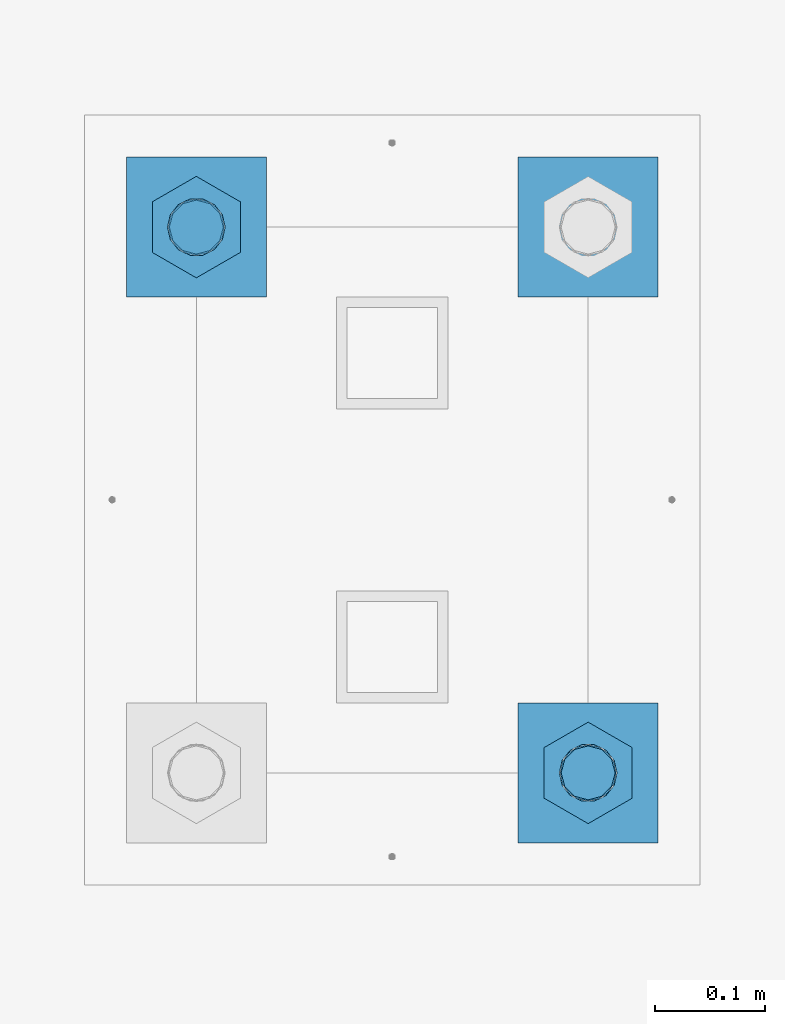
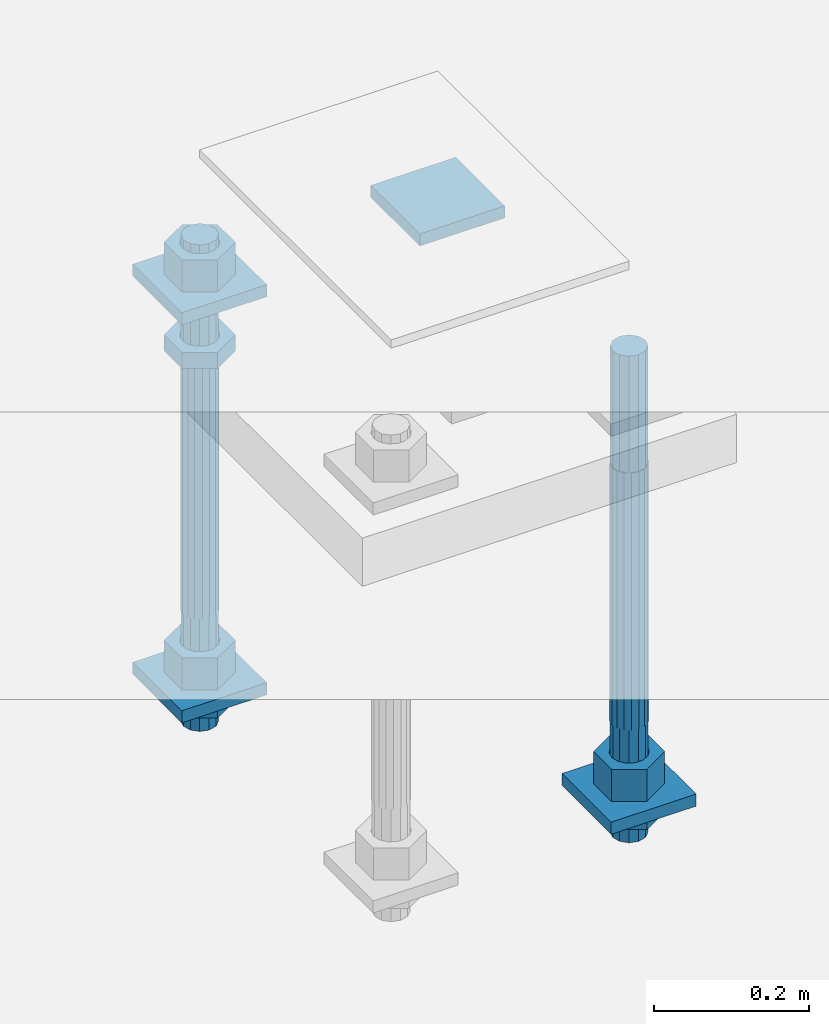
# One storey, part 2764 of 3843: 12 beams, 1 element without a shape of its own.
"""IFC2X3 building model written with IfcOpenShell, lengths in millimetres."""

from ifc_helpers import new_model, si_unit, frame, origin_with_axes, place, context, subcontext, project, spatial, faceted_brep, material, type_object, element, aggregate, save


model = new_model("IFC2X3")

# Units and contexts
model_context = context("Model", 3, precision=1e-05, world=origin_with_axes())
body_context = subcontext(model_context, "Body", "Model", "MODEL_VIEW")
ifc_project = project(units=[si_unit("LENGTHUNIT", "METRE", prefix="MILLI"), si_unit("AREAUNIT", "SQUARE_METRE"), si_unit("VOLUMEUNIT", "CUBIC_METRE"), si_unit("MASSUNIT", "GRAM", prefix="KILO"), si_unit("TIMEUNIT", "SECOND"), si_unit("PLANEANGLEUNIT", "RADIAN"), si_unit("SOLIDANGLEUNIT", "STERADIAN"), si_unit("THERMODYNAMICTEMPERATUREUNIT", "DEGREE_CELSIUS"), si_unit("LUMINOUSINTENSITYUNIT", "LUMEN")], contexts=[model_context])

# Site, building, storey
site_placement = place(None, origin_with_axes())
site = spatial("IfcSite", under=ifc_project, at=site_placement, CompositionType="ELEMENT")
building_placement = place(site_placement, origin_with_axes())
building = spatial("IfcBuilding", under=site, at=building_placement, Name="Undefined", CompositionType="ELEMENT")
storey_placement = place(building_placement, origin_with_axes())
storey = spatial("IfcBuildingStorey", under=building, at=storey_placement, Name="Undefined", CompositionType="ELEMENT", Elevation=0.0)

# Assembly, beams
assembly_placement = place(storey_placement, origin_with_axes())
assembly = element("IfcElementAssembly", 1, at=assembly_placement, inside=storey, Name="TEMPLATE", AssemblyPlace="NOTDEFINED", PredefinedType="RIGID_FRAME")
ifc_material_1 = material(Name="STEEL/A572-50")
beam_type_1 = type_object("IfcBeamType", PredefinedType="NOTDEFINED")
beam_1_placement = place(assembly_placement, frame((111798.100001526, 52952.65, 29873.575), z_axis=(0.0, -1.0, 0.0), x_axis=(1.0, 0.0, 0.0)))
beam_1 = element("IfcBeam", 2, at=beam_1_placement, type_object=beam_type_1, material=ifc_material_1, Name="WASHER_PLATE", context=body_context, shape_type="Brep", body=[
    faceted_brep([(0.0, 9.52500000000146, -63.5), (0.0, 9.52500000000146, 63.5), (127.0, 9.52500000000146, 63.5), (127.0, 9.52500000000146, -63.5), (0.0, -9.52500000000146, 63.5), (127.0, -9.52500000000146, 63.5), (0.0, -9.52500000000146, -63.5), (127.0, -9.52500000000146, -63.5)], [[[0, 1, 2, 3]], [[1, 4, 5, 2]], [[4, 6, 7, 5]], [[6, 0, 3, 7]], [[5, 7, 3, 2]], [[6, 4, 1, 0]]]),
])
beam_2_placement = place(assembly_placement, frame((112153.700001526, 52952.65, 29873.575), z_axis=(0.0, -1.0, 0.0), x_axis=(1.0, 0.0, 0.0)))
beam_2 = element("IfcBeam", 3, at=beam_2_placement, type_object=beam_type_1, material=ifc_material_1, Name="WASHER_PLATE", context=body_context, shape_type="Brep", body=[
    faceted_brep([(0.0, 9.52500000000146, -63.5), (0.0, 9.52500000000146, 63.5), (127.0, 9.52500000000146, 63.5), (127.0, 9.52500000000146, -63.5), (0.0, -9.52500000000146, 63.5), (127.0, -9.52500000000146, 63.5), (0.0, -9.52500000000146, -63.5), (127.0, -9.52500000000146, -63.5)], [[[0, 1, 2, 3]], [[1, 4, 5, 2]], [[4, 6, 7, 5]], [[6, 0, 3, 7]], [[5, 7, 3, 2]], [[6, 4, 1, 0]]]),
])
beam_3_placement = place(assembly_placement, frame((111798.100001526, 52952.65, 29244.925), z_axis=(0.0, -1.0, 0.0), x_axis=(1.0, 0.0, 0.0)))
beam_3 = element("IfcBeam", 4, at=beam_3_placement, type_object=beam_type_1, material=ifc_material_1, Name="WASHER_PLATE", context=body_context, shape_type="Brep", body=[
    faceted_brep([(0.0, 9.52500000000146, -63.5), (0.0, 9.52500000000146, 63.5), (127.0, 9.52500000000146, 63.5), (127.0, 9.52500000000146, -63.5), (0.0, -9.52500000000146, 63.5), (127.0, -9.52500000000146, 63.5), (0.0, -9.52500000000146, -63.5), (127.0, -9.52500000000146, -63.5)], [[[0, 1, 2, 3]], [[1, 4, 5, 2]], [[4, 6, 7, 5]], [[6, 0, 3, 7]], [[5, 7, 3, 2]], [[6, 4, 1, 0]]]),
])
beam_4_placement = place(assembly_placement, frame((112153.700001526, 52457.35, 29244.925), z_axis=(0.0, -1.0, 0.0), x_axis=(1.0, 0.0, 0.0)))
beam_4 = element("IfcBeam", 5, at=beam_4_placement, type_object=beam_type_1, material=ifc_material_1, Name="WASHER_PLATE", context=body_context, shape_type="Brep", body=[
    faceted_brep([(0.0, 9.52500000000146, -63.5), (0.0, 9.52500000000146, 63.5), (127.0, 9.52500000000146, 63.5), (127.0, 9.52500000000146, -63.5), (0.0, -9.52500000000146, 63.5), (127.0, -9.52500000000146, 63.5), (0.0, -9.52500000000146, -63.5), (127.0, -9.52500000000146, -63.5)], [[[0, 1, 2, 3]], [[1, 4, 5, 2]], [[4, 6, 7, 5]], [[6, 0, 3, 7]], [[5, 7, 3, 2]], [[6, 4, 1, 0]]]),
])
ifc_material_2 = material(Name="STEEL/A36")
beam_type_2 = type_object("IfcBeamType", Name="2_HALF_NUT", PredefinedType="NOTDEFINED")
beam_5_placement = place(assembly_placement, frame((111861.600001526, 52952.65, 29787.85), z_axis=(1.0, 0.0, 0.0), x_axis=(0.0, 0.0, -1.0)))
beam_5 = element("IfcBeam", 6, at=beam_5_placement, type_object=beam_type_2, material=ifc_material_2, Name="NUT", ObjectType="2_HALF_NUT", context=body_context, shape_type="Brep", body=[
    faceted_brep([(0.0, -46.0369987487793, 0.0), (0.0, -23.0184993743896, -39.869213104248), (25.4000000000015, -23.0184993743896, -39.869213104248), (25.4000000000015, -46.0369987487793, 0.0), (0.0, 23.0184993743896, -39.869213104248), (25.4000000000015, 23.0184993743896, -39.869213104248), (0.0, 46.0369987487793, 0.0), (25.4000000000015, 46.0369987487793, 0.0), (0.0, 23.0184993743896, 39.869213104248), (25.4000000000015, 23.0184993743896, 39.869213104248), (0.0, -23.0184993743896, 39.869213104248), (25.4000000000015, -23.0184993743896, 39.869213104248), (0.0, 0.0, 26.1940002441406), (0.0, 11.3650617044477, 23.5999013092805), (25.4000000000015, 11.3650617044477, 23.5999013092805), (25.4000000000015, 0.0, 26.1940002441406), (0.0, 20.4791109456419, 16.3316083006721), (25.4000000000015, 20.4791109456419, 16.3316083006721), (0.0, 25.5370200498292, 5.82867859874386), (25.4000000000015, 25.5370200498292, 5.82867859874386), (0.0, 25.5370200498292, -5.82867859874386), (25.4000000000015, 25.5370200498292, -5.82867859874386), (0.0, 20.4791109456419, -16.3316083006721), (25.4000000000015, 20.4791109456419, -16.3316083006721), (0.0, 11.3650617044477, -23.5999013092805), (25.4000000000015, 11.3650617044477, -23.5999013092805), (0.0, 0.0, -26.1940002441406), (25.4000000000015, 0.0, -26.1940002441406), (0.0, -11.3650617044477, -23.5999013092805), (25.4000000000015, -11.3650617044477, -23.5999013092805), (0.0, -20.4791109456419, -16.3316083006721), (25.4000000000015, -20.4791109456419, -16.3316083006721), (0.0, -25.5370200498292, -5.82867859874386), (25.4000000000015, -25.5370200498292, -5.82867859874386), (0.0, -25.5370200498292, 5.82867859874386), (25.4000000000015, -25.5370200498292, 5.82867859874386), (0.0, -20.4791109456419, 16.3316083006721), (25.4000000000015, -20.4791109456419, 16.3316083006721), (0.0, -11.3650617044477, 23.5999013092805), (25.4000000000015, -11.3650617044477, 23.5999013092805)], [[[0, 1, 2, 3]], [[1, 4, 5, 2]], [[4, 6, 7, 5]], [[6, 8, 9, 7]], [[8, 10, 11, 9]], [[10, 0, 3, 11]], [[12, 13, 14, 15]], [[13, 16, 17, 14]], [[16, 18, 19, 17]], [[18, 20, 21, 19]], [[20, 22, 23, 21]], [[22, 24, 25, 23]], [[24, 26, 27, 25]], [[26, 28, 29, 27]], [[28, 30, 31, 29]], [[30, 32, 33, 31]], [[32, 34, 35, 33]], [[34, 36, 37, 35]], [[36, 38, 39, 37]], [[38, 12, 15, 39]], [[5, 7, 9, 11, 3, 2], [17, 19, 21, 23, 25, 27, 29, 31, 33, 35, 37, 39, 15, 14]], [[10, 8, 6, 4, 1, 0], [38, 36, 34, 32, 30, 28, 26, 24, 22, 20, 18, 16, 13, 12]]]),
])
beam_6_placement = place(assembly_placement, frame((111861.600001526, 52952.65, 29235.4), z_axis=(1.0, 0.0, 0.0), x_axis=(0.0, 0.0, -1.0)))
beam_6 = element("IfcBeam", 7, at=beam_6_placement, type_object=beam_type_2, material=ifc_material_2, Name="NUT", ObjectType="2_HALF_NUT", context=body_context, shape_type="Brep", body=[
    faceted_brep([(0.0, -46.0369987487793, 0.0), (0.0, -23.0184993743896, -39.869213104248), (25.4000000000015, -23.0184993743896, -39.869213104248), (25.4000000000015, -46.0369987487793, 0.0), (0.0, 23.0184993743896, -39.869213104248), (25.4000000000015, 23.0184993743896, -39.869213104248), (0.0, 46.0369987487793, 0.0), (25.4000000000015, 46.0369987487793, 0.0), (0.0, 23.0184993743896, 39.869213104248), (25.4000000000015, 23.0184993743896, 39.869213104248), (0.0, -23.0184993743896, 39.869213104248), (25.4000000000015, -23.0184993743896, 39.869213104248), (0.0, 0.0, 26.1940002441406), (0.0, 11.3650617044477, 23.5999013092805), (25.4000000000015, 11.3650617044477, 23.5999013092805), (25.4000000000015, 0.0, 26.1940002441406), (0.0, 20.4791109456419, 16.3316083006721), (25.4000000000015, 20.4791109456419, 16.3316083006721), (0.0, 25.5370200498292, 5.82867859874386), (25.4000000000015, 25.5370200498292, 5.82867859874386), (0.0, 25.5370200498292, -5.82867859874386), (25.4000000000015, 25.5370200498292, -5.82867859874386), (0.0, 20.4791109456419, -16.3316083006721), (25.4000000000015, 20.4791109456419, -16.3316083006721), (0.0, 11.3650617044477, -23.5999013092805), (25.4000000000015, 11.3650617044477, -23.5999013092805), (0.0, 0.0, -26.1940002441406), (25.4000000000015, 0.0, -26.1940002441406), (0.0, -11.3650617044477, -23.5999013092805), (25.4000000000015, -11.3650617044477, -23.5999013092805), (0.0, -20.4791109456419, -16.3316083006721), (25.4000000000015, -20.4791109456419, -16.3316083006721), (0.0, -25.5370200498292, -5.82867859874386), (25.4000000000015, -25.5370200498292, -5.82867859874386), (0.0, -25.5370200498292, 5.82867859874386), (25.4000000000015, -25.5370200498292, 5.82867859874386), (0.0, -20.4791109456419, 16.3316083006721), (25.4000000000015, -20.4791109456419, 16.3316083006721), (0.0, -11.3650617044477, 23.5999013092805), (25.4000000000015, -11.3650617044477, 23.5999013092805)], [[[0, 1, 2, 3]], [[1, 4, 5, 2]], [[4, 6, 7, 5]], [[6, 8, 9, 7]], [[8, 10, 11, 9]], [[10, 0, 3, 11]], [[12, 13, 14, 15]], [[13, 16, 17, 14]], [[16, 18, 19, 17]], [[18, 20, 21, 19]], [[20, 22, 23, 21]], [[22, 24, 25, 23]], [[24, 26, 27, 25]], [[26, 28, 29, 27]], [[28, 30, 31, 29]], [[30, 32, 33, 31]], [[32, 34, 35, 33]], [[34, 36, 37, 35]], [[36, 38, 39, 37]], [[38, 12, 15, 39]], [[5, 7, 9, 11, 3, 2], [17, 19, 21, 23, 25, 27, 29, 31, 33, 35, 37, 39, 15, 14]], [[10, 8, 6, 4, 1, 0], [38, 36, 34, 32, 30, 28, 26, 24, 22, 20, 18, 16, 13, 12]]]),
])
beam_7_placement = place(assembly_placement, frame((112217.200001526, 52457.35, 29235.4), z_axis=(1.0, 0.0, 0.0), x_axis=(0.0, 0.0, -1.0)))
beam_7 = element("IfcBeam", 8, at=beam_7_placement, type_object=beam_type_2, material=ifc_material_2, Name="NUT", ObjectType="2_HALF_NUT", context=body_context, shape_type="Brep", body=[
    faceted_brep([(0.0, -46.0369987487793, 0.0), (0.0, -23.0184993743896, -39.869213104248), (25.4000000000015, -23.0184993743896, -39.869213104248), (25.4000000000015, -46.0369987487793, 0.0), (0.0, 23.0184993743896, -39.869213104248), (25.4000000000015, 23.0184993743896, -39.869213104248), (0.0, 46.0369987487793, 0.0), (25.4000000000015, 46.0369987487793, 0.0), (0.0, 23.0184993743896, 39.869213104248), (25.4000000000015, 23.0184993743896, 39.869213104248), (0.0, -23.0184993743896, 39.869213104248), (25.4000000000015, -23.0184993743896, 39.869213104248), (0.0, 0.0, 26.1940002441406), (0.0, 11.3650617044477, 23.5999013092805), (25.4000000000015, 11.3650617044477, 23.5999013092805), (25.4000000000015, 0.0, 26.1940002441406), (0.0, 20.4791109456419, 16.3316083006721), (25.4000000000015, 20.4791109456419, 16.3316083006721), (0.0, 25.5370200498292, 5.82867859874386), (25.4000000000015, 25.5370200498292, 5.82867859874386), (0.0, 25.5370200498292, -5.82867859874386), (25.4000000000015, 25.5370200498292, -5.82867859874386), (0.0, 20.4791109456419, -16.3316083006721), (25.4000000000015, 20.4791109456419, -16.3316083006721), (0.0, 11.3650617044477, -23.5999013092805), (25.4000000000015, 11.3650617044477, -23.5999013092805), (0.0, 0.0, -26.1940002441406), (25.4000000000015, 0.0, -26.1940002441406), (0.0, -11.3650617044477, -23.5999013092805), (25.4000000000015, -11.3650617044477, -23.5999013092805), (0.0, -20.4791109456419, -16.3316083006721), (25.4000000000015, -20.4791109456419, -16.3316083006721), (0.0, -25.5370200498292, -5.82867859874386), (25.4000000000015, -25.5370200498292, -5.82867859874386), (0.0, -25.5370200498292, 5.82867859874386), (25.4000000000015, -25.5370200498292, 5.82867859874386), (0.0, -20.4791109456419, 16.3316083006721), (25.4000000000015, -20.4791109456419, 16.3316083006721), (0.0, -11.3650617044477, 23.5999013092805), (25.4000000000015, -11.3650617044477, 23.5999013092805)], [[[0, 1, 2, 3]], [[1, 4, 5, 2]], [[4, 6, 7, 5]], [[6, 8, 9, 7]], [[8, 10, 11, 9]], [[10, 0, 3, 11]], [[12, 13, 14, 15]], [[13, 16, 17, 14]], [[16, 18, 19, 17]], [[18, 20, 21, 19]], [[20, 22, 23, 21]], [[22, 24, 25, 23]], [[24, 26, 27, 25]], [[26, 28, 29, 27]], [[28, 30, 31, 29]], [[30, 32, 33, 31]], [[32, 34, 35, 33]], [[34, 36, 37, 35]], [[36, 38, 39, 37]], [[38, 12, 15, 39]], [[5, 7, 9, 11, 3, 2], [17, 19, 21, 23, 25, 27, 29, 31, 33, 35, 37, 39, 15, 14]], [[10, 8, 6, 4, 1, 0], [38, 36, 34, 32, 30, 28, 26, 24, 22, 20, 18, 16, 13, 12]]]),
])
beam_type_3 = type_object("IfcBeamType", Name="2_HEAVY_HEX_NUT", PredefinedType="NOTDEFINED")
beam_8_placement = place(assembly_placement, frame((111861.600001526, 52952.65, 29933.9), z_axis=(1.0, 0.0, 0.0), x_axis=(0.0, 0.0, -1.0)))
beam_8 = element("IfcBeam", 9, at=beam_8_placement, type_object=beam_type_3, material=ifc_material_2, Name="NUT", ObjectType="2_HEAVY_HEX_NUT", context=body_context, shape_type="Brep", body=[
    faceted_brep([(0.0, -46.0369987487793, 0.0), (0.0, -23.0184993743896, -39.869213104248), (50.7999999999993, -23.0184993743896, -39.869213104248), (50.7999999999993, -46.0369987487793, 0.0), (0.0, 23.0184993743896, -39.869213104248), (50.7999999999993, 23.0184993743896, -39.869213104248), (0.0, 46.0369987487793, 0.0), (50.7999999999993, 46.0369987487793, 0.0), (0.0, 23.0184993743896, 39.869213104248), (50.7999999999993, 23.0184993743896, 39.869213104248), (0.0, -23.0184993743896, 39.869213104248), (50.7999999999993, -23.0184993743896, 39.869213104248), (0.0, 0.0, 26.1940002441406), (0.0, 11.3650617044477, 23.5999013092805), (50.7999999999993, 11.3650617044477, 23.5999013092805), (50.7999999999993, 0.0, 26.1940002441406), (0.0, 20.4791109456419, 16.3316083006721), (50.7999999999993, 20.4791109456419, 16.3316083006721), (0.0, 25.5370200498292, 5.82867859874386), (50.7999999999993, 25.5370200498292, 5.82867859874386), (0.0, 25.5370200498292, -5.82867859874386), (50.7999999999993, 25.5370200498292, -5.82867859874386), (0.0, 20.4791109456419, -16.3316083006721), (50.7999999999993, 20.4791109456419, -16.3316083006721), (0.0, 11.3650617044477, -23.5999013092805), (50.7999999999993, 11.3650617044477, -23.5999013092805), (0.0, 0.0, -26.1940002441406), (50.7999999999993, 0.0, -26.1940002441406), (0.0, -11.3650617044477, -23.5999013092805), (50.7999999999993, -11.3650617044477, -23.5999013092805), (0.0, -20.4791109456419, -16.3316083006721), (50.7999999999993, -20.4791109456419, -16.3316083006721), (0.0, -25.5370200498292, -5.82867859874386), (50.7999999999993, -25.5370200498292, -5.82867859874386), (0.0, -25.5370200498292, 5.82867859874386), (50.7999999999993, -25.5370200498292, 5.82867859874386), (0.0, -20.4791109456419, 16.3316083006721), (50.7999999999993, -20.4791109456419, 16.3316083006721), (0.0, -11.3650617044477, 23.5999013092805), (50.7999999999993, -11.3650617044477, 23.5999013092805)], [[[0, 1, 2, 3]], [[1, 4, 5, 2]], [[4, 6, 7, 5]], [[6, 8, 9, 7]], [[8, 10, 11, 9]], [[10, 0, 3, 11]], [[12, 13, 14, 15]], [[13, 16, 17, 14]], [[16, 18, 19, 17]], [[18, 20, 21, 19]], [[20, 22, 23, 21]], [[22, 24, 25, 23]], [[24, 26, 27, 25]], [[26, 28, 29, 27]], [[28, 30, 31, 29]], [[30, 32, 33, 31]], [[32, 34, 35, 33]], [[34, 36, 37, 35]], [[36, 38, 39, 37]], [[38, 12, 15, 39]], [[5, 7, 9, 11, 3, 2], [17, 19, 21, 23, 25, 27, 29, 31, 33, 35, 37, 39, 15, 14]], [[10, 8, 6, 4, 1, 0], [38, 36, 34, 32, 30, 28, 26, 24, 22, 20, 18, 16, 13, 12]]]),
])
beam_9_placement = place(assembly_placement, frame((111861.600001526, 52952.65, 29305.25), z_axis=(1.0, 0.0, 0.0), x_axis=(0.0, 0.0, -1.0)))
beam_9 = element("IfcBeam", 10, at=beam_9_placement, type_object=beam_type_3, material=ifc_material_2, Name="NUT", ObjectType="2_HEAVY_HEX_NUT", context=body_context, shape_type="Brep", body=[
    faceted_brep([(0.0, -46.0369987487793, 0.0), (0.0, -23.0184993743896, -39.869213104248), (50.7999999999993, -23.0184993743896, -39.869213104248), (50.7999999999993, -46.0369987487793, 0.0), (0.0, 23.0184993743896, -39.869213104248), (50.7999999999993, 23.0184993743896, -39.869213104248), (0.0, 46.0369987487793, 0.0), (50.7999999999993, 46.0369987487793, 0.0), (0.0, 23.0184993743896, 39.869213104248), (50.7999999999993, 23.0184993743896, 39.869213104248), (0.0, -23.0184993743896, 39.869213104248), (50.7999999999993, -23.0184993743896, 39.869213104248), (0.0, 0.0, 26.1940002441406), (0.0, 11.3650617044477, 23.5999013092805), (50.7999999999993, 11.3650617044477, 23.5999013092805), (50.7999999999993, 0.0, 26.1940002441406), (0.0, 20.4791109456419, 16.3316083006721), (50.7999999999993, 20.4791109456419, 16.3316083006721), (0.0, 25.5370200498292, 5.82867859874386), (50.7999999999993, 25.5370200498292, 5.82867859874386), (0.0, 25.5370200498292, -5.82867859874386), (50.7999999999993, 25.5370200498292, -5.82867859874386), (0.0, 20.4791109456419, -16.3316083006721), (50.7999999999993, 20.4791109456419, -16.3316083006721), (0.0, 11.3650617044477, -23.5999013092805), (50.7999999999993, 11.3650617044477, -23.5999013092805), (0.0, 0.0, -26.1940002441406), (50.7999999999993, 0.0, -26.1940002441406), (0.0, -11.3650617044477, -23.5999013092805), (50.7999999999993, -11.3650617044477, -23.5999013092805), (0.0, -20.4791109456419, -16.3316083006721), (50.7999999999993, -20.4791109456419, -16.3316083006721), (0.0, -25.5370200498292, -5.82867859874386), (50.7999999999993, -25.5370200498292, -5.82867859874386), (0.0, -25.5370200498292, 5.82867859874386), (50.7999999999993, -25.5370200498292, 5.82867859874386), (0.0, -20.4791109456419, 16.3316083006721), (50.7999999999993, -20.4791109456419, 16.3316083006721), (0.0, -11.3650617044477, 23.5999013092805), (50.7999999999993, -11.3650617044477, 23.5999013092805)], [[[0, 1, 2, 3]], [[1, 4, 5, 2]], [[4, 6, 7, 5]], [[6, 8, 9, 7]], [[8, 10, 11, 9]], [[10, 0, 3, 11]], [[12, 13, 14, 15]], [[13, 16, 17, 14]], [[16, 18, 19, 17]], [[18, 20, 21, 19]], [[20, 22, 23, 21]], [[22, 24, 25, 23]], [[24, 26, 27, 25]], [[26, 28, 29, 27]], [[28, 30, 31, 29]], [[30, 32, 33, 31]], [[32, 34, 35, 33]], [[34, 36, 37, 35]], [[36, 38, 39, 37]], [[38, 12, 15, 39]], [[5, 7, 9, 11, 3, 2], [17, 19, 21, 23, 25, 27, 29, 31, 33, 35, 37, 39, 15, 14]], [[10, 8, 6, 4, 1, 0], [38, 36, 34, 32, 30, 28, 26, 24, 22, 20, 18, 16, 13, 12]]]),
])
beam_10_placement = place(assembly_placement, frame((112217.200001526, 52457.35, 29305.25), z_axis=(1.0, 0.0, 0.0), x_axis=(0.0, 0.0, -1.0)))
beam_10 = element("IfcBeam", 11, at=beam_10_placement, type_object=beam_type_3, material=ifc_material_2, Name="NUT", ObjectType="2_HEAVY_HEX_NUT", context=body_context, shape_type="Brep", body=[
    faceted_brep([(0.0, -46.0369987487793, 0.0), (0.0, -23.0184993743896, -39.869213104248), (50.7999999999993, -23.0184993743896, -39.869213104248), (50.7999999999993, -46.0369987487793, 0.0), (0.0, 23.0184993743896, -39.869213104248), (50.7999999999993, 23.0184993743896, -39.869213104248), (0.0, 46.0369987487793, 0.0), (50.7999999999993, 46.0369987487793, 0.0), (0.0, 23.0184993743896, 39.869213104248), (50.7999999999993, 23.0184993743896, 39.869213104248), (0.0, -23.0184993743896, 39.869213104248), (50.7999999999993, -23.0184993743896, 39.869213104248), (0.0, 0.0, 26.1940002441406), (0.0, 11.3650617044477, 23.5999013092805), (50.7999999999993, 11.3650617044477, 23.5999013092805), (50.7999999999993, 0.0, 26.1940002441406), (0.0, 20.4791109456419, 16.3316083006721), (50.7999999999993, 20.4791109456419, 16.3316083006721), (0.0, 25.5370200498292, 5.82867859874386), (50.7999999999993, 25.5370200498292, 5.82867859874386), (0.0, 25.5370200498292, -5.82867859874386), (50.7999999999993, 25.5370200498292, -5.82867859874386), (0.0, 20.4791109456419, -16.3316083006721), (50.7999999999993, 20.4791109456419, -16.3316083006721), (0.0, 11.3650617044477, -23.5999013092805), (50.7999999999993, 11.3650617044477, -23.5999013092805), (0.0, 0.0, -26.1940002441406), (50.7999999999993, 0.0, -26.1940002441406), (0.0, -11.3650617044477, -23.5999013092805), (50.7999999999993, -11.3650617044477, -23.5999013092805), (0.0, -20.4791109456419, -16.3316083006721), (50.7999999999993, -20.4791109456419, -16.3316083006721), (0.0, -25.5370200498292, -5.82867859874386), (50.7999999999993, -25.5370200498292, -5.82867859874386), (0.0, -25.5370200498292, 5.82867859874386), (50.7999999999993, -25.5370200498292, 5.82867859874386), (0.0, -20.4791109456419, 16.3316083006721), (50.7999999999993, -20.4791109456419, 16.3316083006721), (0.0, -11.3650617044477, 23.5999013092805), (50.7999999999993, -11.3650617044477, 23.5999013092805)], [[[0, 1, 2, 3]], [[1, 4, 5, 2]], [[4, 6, 7, 5]], [[6, 8, 9, 7]], [[8, 10, 11, 9]], [[10, 0, 3, 11]], [[12, 13, 14, 15]], [[13, 16, 17, 14]], [[16, 18, 19, 17]], [[18, 20, 21, 19]], [[20, 22, 23, 21]], [[22, 24, 25, 23]], [[24, 26, 27, 25]], [[26, 28, 29, 27]], [[28, 30, 31, 29]], [[30, 32, 33, 31]], [[32, 34, 35, 33]], [[34, 36, 37, 35]], [[36, 38, 39, 37]], [[38, 12, 15, 39]], [[5, 7, 9, 11, 3, 2], [17, 19, 21, 23, 25, 27, 29, 31, 33, 35, 37, 39, 15, 14]], [[10, 8, 6, 4, 1, 0], [38, 36, 34, 32, 30, 28, 26, 24, 22, 20, 18, 16, 13, 12]]]),
])
ifc_material_3 = material()
beam_type_4 = type_object("IfcBeamType", PredefinedType="NOTDEFINED")
beam_11_placement = place(assembly_placement, frame((111861.600001526, 52952.65, 29762.45), z_axis=(1.0, 0.0, 0.0), x_axis=(0.0, 0.0, -1.0)))
beam_11 = element("IfcBeam", 12, at=beam_11_placement, type_object=beam_type_4, material=ifc_material_3, Name="ANCHOR_ROD", context=body_context, shape_type="Brep", body=[
    faceted_brep([(-184.150000000001, -21.217622392709, 12.25), (-184.150000000001, -12.2499999999854, 21.2176223927163), (-184.150000000001, 1.45519152283669e-11, 24.5), (-184.150000000001, 12.2500000000146, 21.2176223927163), (-184.150000000001, 21.2176223927381, 12.25), (-184.150000000001, 24.5000000000146, 0.0), (-184.150000000001, 21.2176223927381, -12.25), (-184.150000000001, 12.2500000000146, -21.2176223927163), (-184.150000000001, 1.45519152283669e-11, -24.5), (-184.150000000001, -12.2499999999854, -21.2176223927163), (-184.150000000001, -21.217622392709, -12.25), (-184.150000000001, -24.4999999999854, 0.0), (0.0, 24.5000000000146, 0.0), (0.0, 21.2176223927381, -12.25), (0.0, 12.2500000000146, -21.2176223927163), (0.0, 1.45519152283669e-11, -24.5), (0.0, -12.2499999999854, -21.2176223927163), (0.0, -21.217622392709, -12.25), (0.0, -24.4999999999854, 0.0), (0.0, -21.217622392709, 12.25), (0.0, -12.2499999999854, 21.2176223927163), (0.0, 1.45519152283669e-11, 24.5), (0.0, 12.2500000000146, 21.2176223927163), (0.0, 21.2176223927381, 12.25), (0.0, -23.4665401257807, 9.72015918207035), (0.0, -17.9605122421344, 17.9605122421417), (0.0, -9.72015918207762, 23.466540125788), (0.0, 0.0, 25.4000000000015), (0.0, 9.72015918207762, 23.466540125788), (0.0, 17.9605122421344, 17.9605122421417), (0.0, 23.4665401257807, 9.72015918207035), (0.0, 25.3999996185303, 0.0), (0.0, 23.4665401257807, -9.72015918207035), (0.0, 17.9605122421344, -17.9605122421417), (0.0, 9.72015918207762, -23.466540125788), (0.0, 0.0, -25.4000000000015), (0.0, -9.72015918207762, -23.466540125788), (0.0, -17.9605122421344, -17.9605122421417), (0.0, -23.4665401257807, -9.72015918207035), (0.0, -25.3999996185303, 0.0), (406.399999999998, -25.3999999999942, 0.0), (406.399999999998, -23.4665401257807, 9.72015918207035), (406.399999999998, -17.9605122421344, 17.9605122421417), (406.399999999998, -9.72015918207762, 23.466540125788), (406.399999999998, 0.0, 25.4000000000015), (406.399999999998, 9.72015918207762, 23.466540125788), (406.399999999998, 17.9605122421344, 17.9605122421417), (406.399999999998, 23.4665401257807, 9.72015918207035), (406.399999999998, 25.3999999999942, 0.0), (406.399999999998, 23.4665401257807, -9.72015918207035), (406.399999999998, 17.9605122421344, -17.9605122421417), (406.399999999998, 9.72015918207762, -23.466540125788), (406.399999999998, 0.0, -25.4000000000015), (406.399999999998, -9.72015918207762, -23.466540125788), (406.399999999998, -17.9605122421344, -17.9605122421417), (406.399999999998, -23.4665401257807, -9.72015918207035), (406.399999999998, -12.2499999999854, 21.2176223927163), (406.399999999998, 1.45519152283669e-11, 24.5), (406.399999999998, 12.2500000000146, 21.2176223927163), (406.399999999998, 21.2176223927381, 12.25), (406.399999999998, 24.5000000000146, 0.0), (406.399999999998, 21.2176223927381, -12.25), (406.399999999998, 12.2500000000146, -21.2176223927163), (406.399999999998, 1.45519152283669e-11, -24.5), (406.399999999998, -12.2499999999854, -21.2176223927163), (406.399999999998, -21.217622392709, -12.25), (406.399999999998, -24.4999999999854, 0.0), (406.399999999998, -21.217622392709, 12.25), (584.200000000001, -12.2499999999854, -21.2176223927163), (584.200000000001, 1.45519152283669e-11, -24.5), (584.200000000001, 12.2500000000146, -21.2176223927163), (584.200000000001, 21.2176223927381, -12.25), (584.200000000001, 24.5000000000146, 0.0), (584.200000000001, 21.2176223927381, 12.25), (584.200000000001, 12.2500000000146, 21.2176223927163), (584.200000000001, 1.45519152283669e-11, 24.5), (584.200000000001, -12.2499999999854, 21.2176223927163), (584.200000000001, -21.217622392709, 12.25), (584.200000000001, -24.4999999999854, 0.0), (584.200000000001, -21.217622392709, -12.25)], [[[0, 1, 2, 3, 4, 5, 6, 7, 8, 9, 10, 11]], [[6, 5, 12, 13]], [[7, 6, 13, 14]], [[8, 7, 14, 15]], [[9, 8, 15, 16]], [[10, 9, 16, 17]], [[11, 10, 17, 18]], [[0, 11, 18, 19]], [[1, 0, 19, 20]], [[2, 1, 20, 21]], [[3, 2, 21, 22]], [[4, 3, 22, 23]], [[5, 4, 23, 12]], [[24, 25, 26, 27, 28, 29, 30, 31, 32, 33, 34, 35, 36, 37, 38, 39], [22, 21, 20, 19, 18, 17, 16, 15, 14, 13, 12, 23]], [[24, 39, 40, 41]], [[25, 24, 41, 42]], [[26, 25, 42, 43]], [[27, 26, 43, 44]], [[28, 27, 44, 45]], [[29, 28, 45, 46]], [[30, 29, 46, 47]], [[31, 30, 47, 48]], [[32, 31, 48, 49]], [[33, 32, 49, 50]], [[34, 33, 50, 51]], [[35, 34, 51, 52]], [[36, 35, 52, 53]], [[37, 36, 53, 54]], [[38, 37, 54, 55]], [[39, 38, 55, 40]], [[54, 53, 52, 51, 50, 49, 48, 47, 46, 45, 44, 43, 42, 41, 40, 55], [56, 57, 58, 59, 60, 61, 62, 63, 64, 65, 66, 67]], [[68, 69, 70, 71, 72, 73, 74, 75, 76, 77, 78, 79]], [[76, 75, 57, 56]], [[77, 76, 56, 67]], [[78, 77, 67, 66]], [[79, 78, 66, 65]], [[68, 79, 65, 64]], [[69, 68, 64, 63]], [[70, 69, 63, 62]], [[71, 70, 62, 61]], [[72, 71, 61, 60]], [[73, 72, 60, 59]], [[74, 73, 59, 58]], [[75, 74, 58, 57]]]),
])
beam_12_placement = place(assembly_placement, frame((112217.200001526, 52457.35, 29762.45), z_axis=(1.0, 0.0, 0.0), x_axis=(0.0, 0.0, -1.0)))
beam_12 = element("IfcBeam", 13, at=beam_12_placement, type_object=beam_type_4, material=ifc_material_3, Name="ANCHOR_ROD", context=body_context, shape_type="Brep", body=[
    faceted_brep([(-184.150000000001, -21.217622392709, 12.25), (-184.150000000001, -12.2499999999854, 21.2176223927163), (-184.150000000001, 1.45519152283669e-11, 24.5), (-184.150000000001, 12.2500000000146, 21.2176223927163), (-184.150000000001, 21.2176223927381, 12.25), (-184.150000000001, 24.5000000000146, 0.0), (-184.150000000001, 21.2176223927381, -12.25), (-184.150000000001, 12.2500000000146, -21.2176223927163), (-184.150000000001, 1.45519152283669e-11, -24.5), (-184.150000000001, -12.2499999999854, -21.2176223927163), (-184.150000000001, -21.217622392709, -12.25), (-184.150000000001, -24.4999999999854, 0.0), (0.0, 24.5000000000146, 0.0), (0.0, 21.2176223927381, -12.25), (0.0, 12.2500000000146, -21.2176223927163), (0.0, 1.45519152283669e-11, -24.5), (0.0, -12.2499999999854, -21.2176223927163), (0.0, -21.217622392709, -12.25), (0.0, -24.4999999999854, 0.0), (0.0, -21.217622392709, 12.25), (0.0, -12.2499999999854, 21.2176223927163), (0.0, 1.45519152283669e-11, 24.5), (0.0, 12.2500000000146, 21.2176223927163), (0.0, 21.2176223927381, 12.25), (0.0, -23.4665401257807, 9.72015918207035), (0.0, -17.9605122421344, 17.9605122421417), (0.0, -9.72015918207762, 23.466540125788), (0.0, 0.0, 25.4000000000015), (0.0, 9.72015918207762, 23.466540125788), (0.0, 17.9605122421344, 17.9605122421417), (0.0, 23.4665401257807, 9.72015918207035), (0.0, 25.3999996185303, 0.0), (0.0, 23.4665401257807, -9.72015918207035), (0.0, 17.9605122421344, -17.9605122421417), (0.0, 9.72015918207762, -23.466540125788), (0.0, 0.0, -25.4000000000015), (0.0, -9.72015918207762, -23.466540125788), (0.0, -17.9605122421344, -17.9605122421417), (0.0, -23.4665401257807, -9.72015918207035), (0.0, -25.3999996185303, 0.0), (406.399999999998, -25.3999999999942, 0.0), (406.399999999998, -23.4665401257807, 9.72015918207035), (406.399999999998, -17.9605122421344, 17.9605122421417), (406.399999999998, -9.72015918207762, 23.466540125788), (406.399999999998, 0.0, 25.4000000000015), (406.399999999998, 9.72015918207762, 23.466540125788), (406.399999999998, 17.9605122421344, 17.9605122421417), (406.399999999998, 23.4665401257807, 9.72015918207035), (406.399999999998, 25.3999999999942, 0.0), (406.399999999998, 23.4665401257807, -9.72015918207035), (406.399999999998, 17.9605122421344, -17.9605122421417), (406.399999999998, 9.72015918207762, -23.466540125788), (406.399999999998, 0.0, -25.4000000000015), (406.399999999998, -9.72015918207762, -23.466540125788), (406.399999999998, -17.9605122421344, -17.9605122421417), (406.399999999998, -23.4665401257807, -9.72015918207035), (406.399999999998, -12.2499999999854, 21.2176223927163), (406.399999999998, 1.45519152283669e-11, 24.5), (406.399999999998, 12.2500000000146, 21.2176223927163), (406.399999999998, 21.2176223927381, 12.25), (406.399999999998, 24.5000000000146, 0.0), (406.399999999998, 21.2176223927381, -12.25), (406.399999999998, 12.2500000000146, -21.2176223927163), (406.399999999998, 1.45519152283669e-11, -24.5), (406.399999999998, -12.2499999999854, -21.2176223927163), (406.399999999998, -21.217622392709, -12.25), (406.399999999998, -24.4999999999854, 0.0), (406.399999999998, -21.217622392709, 12.25), (584.200000000001, -12.2499999999854, -21.2176223927163), (584.200000000001, 1.45519152283669e-11, -24.5), (584.200000000001, 12.2500000000146, -21.2176223927163), (584.200000000001, 21.2176223927381, -12.25), (584.200000000001, 24.5000000000146, 0.0), (584.200000000001, 21.2176223927381, 12.25), (584.200000000001, 12.2500000000146, 21.2176223927163), (584.200000000001, 1.45519152283669e-11, 24.5), (584.200000000001, -12.2499999999854, 21.2176223927163), (584.200000000001, -21.217622392709, 12.25), (584.200000000001, -24.4999999999854, 0.0), (584.200000000001, -21.217622392709, -12.25)], [[[0, 1, 2, 3, 4, 5, 6, 7, 8, 9, 10, 11]], [[6, 5, 12, 13]], [[7, 6, 13, 14]], [[8, 7, 14, 15]], [[9, 8, 15, 16]], [[10, 9, 16, 17]], [[11, 10, 17, 18]], [[0, 11, 18, 19]], [[1, 0, 19, 20]], [[2, 1, 20, 21]], [[3, 2, 21, 22]], [[4, 3, 22, 23]], [[5, 4, 23, 12]], [[24, 25, 26, 27, 28, 29, 30, 31, 32, 33, 34, 35, 36, 37, 38, 39], [22, 21, 20, 19, 18, 17, 16, 15, 14, 13, 12, 23]], [[24, 39, 40, 41]], [[25, 24, 41, 42]], [[26, 25, 42, 43]], [[27, 26, 43, 44]], [[28, 27, 44, 45]], [[29, 28, 45, 46]], [[30, 29, 46, 47]], [[31, 30, 47, 48]], [[32, 31, 48, 49]], [[33, 32, 49, 50]], [[34, 33, 50, 51]], [[35, 34, 51, 52]], [[36, 35, 52, 53]], [[37, 36, 53, 54]], [[38, 37, 54, 55]], [[39, 38, 55, 40]], [[54, 53, 52, 51, 50, 49, 48, 47, 46, 45, 44, 43, 42, 41, 40, 55], [56, 57, 58, 59, 60, 61, 62, 63, 64, 65, 66, 67]], [[68, 69, 70, 71, 72, 73, 74, 75, 76, 77, 78, 79]], [[76, 75, 57, 56]], [[77, 76, 56, 67]], [[78, 77, 67, 66]], [[79, 78, 66, 65]], [[68, 79, 65, 64]], [[69, 68, 64, 63]], [[70, 69, 63, 62]], [[71, 70, 62, 61]], [[72, 71, 61, 60]], [[73, 72, 60, 59]], [[74, 73, 59, 58]], [[75, 74, 58, 57]]]),
])
aggregate(assembly, [beam_1, beam_2, beam_5, beam_8, beam_9, beam_6, beam_3, beam_11, beam_10, beam_7, beam_4, beam_12])

save(model, "model.ifc")
